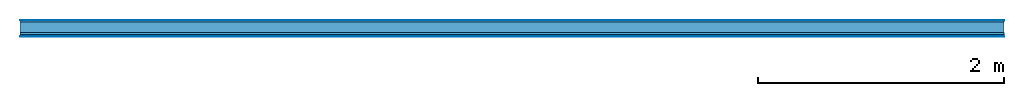
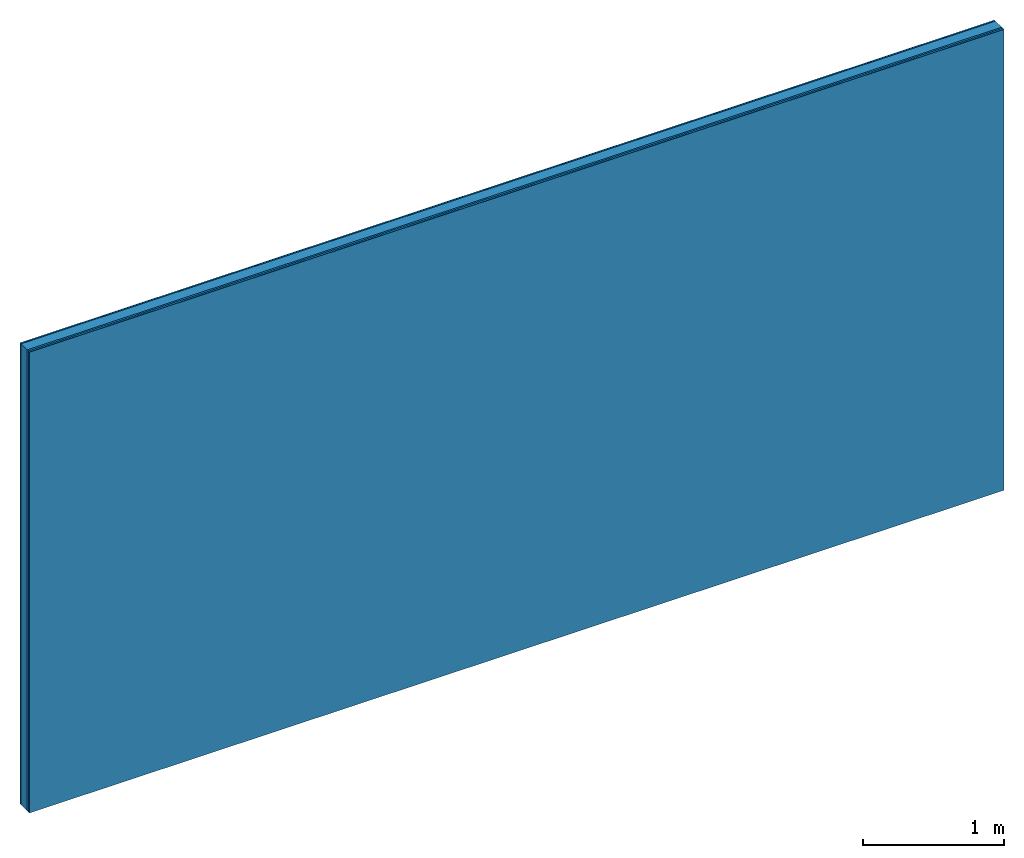
# One storey: 5 plates, 1 member, 1 element without a shape of its own.
"""IFC4 building model written with IfcOpenShell, lengths in metres."""

from ifc_helpers import new_model, si_unit, derived_unit, direction, frame, frame_2d, origin, origin_with_axes, place, context, project, spatial, rectangle, extrude, material, layer, layer_set, type_object, element, aggregate, save


model = new_model("IFC4")

# Units and contexts
plan_context = context("Plan", 3, precision=1e-05, world=origin(), true_north=direction((0.0, 1.0)))
model_context = context("Model", 3, precision=1e-05, world=origin(), true_north=direction((0.0, 1.0)))
ifc_project = project(units=[si_unit("LENGTHUNIT", "METRE"), derived_unit("SOUNDPRESSUREUNIT", [(si_unit("PRESSUREUNIT", "PASCAL", prefix="MICRO"), 0)]), si_unit("ENERGYUNIT", "JOULE", prefix="MEGA"), si_unit("MASSUNIT", "GRAM", prefix="KILO"), derived_unit("THERMALTRANSMITTANCEUNIT", [(si_unit("POWERUNIT", "WATT"), 1), (si_unit("AREAUNIT", "SQUARE_METRE"), -1), (si_unit("THERMODYNAMICTEMPERATUREUNIT", "KELVIN"), -1)]), derived_unit("AREADENSITYUNIT", [(si_unit("MASSUNIT", "GRAM", prefix="KILO"), 1), (si_unit("AREAUNIT", "SQUARE_METRE"), -1)]), derived_unit("USERDEFINED", [(si_unit("ENERGYUNIT", "JOULE", prefix="MEGA"), 1), (si_unit("AREAUNIT", "SQUARE_METRE"), -1)])], contexts=[plan_context, model_context])

# Site, building, storey
site = spatial("IfcSite", under=ifc_project)
building_placement = place(None, origin())
building = spatial("IfcBuilding", under=site, at=building_placement)
storey_placement = place(building_placement, origin())
storey = spatial("IfcBuildingStorey", under=building, at=storey_placement)

# Wall, member, plates
ifc_material_1 = material(Category="04.001")
ifc_layer_1 = layer(ifc_material_1, 0.003, Name="Surface")
ifc_material_2 = material(Name="Plasterboard type A", Category="03.008")
ifc_layer_2 = layer(ifc_material_2, 0.0125, Name="1st layer")
ifc_material_3 = material(Name="of the art")
ifc_layer_3 = layer(ifc_material_3, 0.0, Name="Bond")
ifc_layer_4 = layer(None, 0.087, Name="Support")
ifc_layer_5 = layer(ifc_material_3, 0.0, Name="Bond")
ifc_material_4 = material(Name="DFH2IR Knauf Diamant hard- plasterboard", Category="03.007")
ifc_layer_6 = layer(ifc_material_4, 0.015, Name="1st layer")
ifc_layer_7 = layer(ifc_material_4, 0.015, Name="2nd layer")
ifc_layer_8 = layer(ifc_material_1, 0.003, Name="Surface")
ifc_layer_set = layer_set([ifc_layer_1, ifc_layer_2, ifc_layer_3, ifc_layer_4, ifc_layer_5, ifc_layer_6, ifc_layer_7, ifc_layer_8])
wall_type = type_object("IfcWallType", Name="C0367", PredefinedType="NOTDEFINED", material=ifc_layer_set)
wall_placement = place(None, frame((0.0, 0.0, 0.0), z_axis=(0.0, -1.0, 0.0), x_axis=(1.0, 0.0, 0.0)))
wall = element("IfcWall", 1, at=wall_placement, inside=storey, type_object=wall_type, material=ifc_layer_set, Name="Wall #1")
ifc_material_5 = material(Name="Solid timber panel")
member_placement = place(wall_placement, origin())
member = element("IfcMember", 2, at=member_placement, material=ifc_material_5, Name="Support", context=plan_context, shape_type="SweptSolid", body=[
    extrude(rectangle(XDim=1.0, YDim=0.087, at=frame_2d((0.5, 0.0435), x_axis=(1.0, 0.0))), frame((0.0, 4.0, 0.0155), z_axis=(0.0, -1.0, 0.0), x_axis=(1.0, 0.0, 0.0)), (0.0, 0.0, 1.0), 4.0),
    extrude(rectangle(XDim=1.0, YDim=0.087, at=frame_2d((0.5, 0.0435), x_axis=(1.0, 0.0))), frame((1.0, 4.0, 0.0155), z_axis=(0.0, -1.0, 0.0), x_axis=(1.0, 0.0, 0.0)), (0.0, 0.0, 1.0), 4.0),
    extrude(rectangle(XDim=1.0, YDim=0.087, at=frame_2d((0.5, 0.0435), x_axis=(1.0, 0.0))), frame((2.0, 4.0, 0.0155), z_axis=(0.0, -1.0, 0.0), x_axis=(1.0, 0.0, 0.0)), (0.0, 0.0, 1.0), 4.0),
    extrude(rectangle(XDim=1.0, YDim=0.087, at=frame_2d((0.5, 0.0435), x_axis=(1.0, 0.0))), frame((3.0, 4.0, 0.0155), z_axis=(0.0, -1.0, 0.0), x_axis=(1.0, 0.0, 0.0)), (0.0, 0.0, 1.0), 4.0),
    extrude(rectangle(XDim=1.0, YDim=0.087, at=frame_2d((0.5, 0.0435), x_axis=(1.0, 0.0))), frame((4.0, 4.0, 0.0155), z_axis=(0.0, -1.0, 0.0), x_axis=(1.0, 0.0, 0.0)), (0.0, 0.0, 1.0), 4.0),
    extrude(rectangle(XDim=1.0, YDim=0.087, at=frame_2d((0.5, 0.0435), x_axis=(1.0, 0.0))), frame((5.0, 4.0, 0.0155), z_axis=(0.0, -1.0, 0.0), x_axis=(1.0, 0.0, 0.0)), (0.0, 0.0, 1.0), 4.0),
    extrude(rectangle(XDim=1.0, YDim=0.087, at=frame_2d((0.5, 0.0435), x_axis=(1.0, 0.0))), frame((6.0, 4.0, 0.0155), z_axis=(0.0, -1.0, 0.0), x_axis=(1.0, 0.0, 0.0)), (0.0, 0.0, 1.0), 4.0),
    extrude(rectangle(XDim=1.0, YDim=0.087, at=frame_2d((0.5, 0.0435), x_axis=(1.0, 0.0))), frame((7.0, 4.0, 0.0155), z_axis=(0.0, -1.0, 0.0), x_axis=(1.0, 0.0, 0.0)), (0.0, 0.0, 1.0), 4.0),
])
plate_1_placement = place(wall_placement, origin())
plate_1 = element("IfcPlate", 3, at=plate_1_placement, material=ifc_material_1, Name="Surface", context=plan_context, shape_type="SweptSolid", body=[
    extrude(rectangle(XDim=8.0, YDim=4.0, at=frame_2d((4.0, 2.0), x_axis=(1.0, 0.0))), origin_with_axes(), (0.0, 0.0, 1.0), 0.003),
])
plate_2_placement = place(wall_placement, origin())
plate_2 = element("IfcPlate", 4, at=plate_2_placement, material=ifc_material_2, Name="1st layer", context=plan_context, shape_type="SweptSolid", body=[
    extrude(rectangle(XDim=8.0, YDim=4.0, at=frame_2d((4.0, 2.0), x_axis=(1.0, 0.0))), frame((0.0, 0.0, 0.003), z_axis=(0.0, 0.0, 1.0), x_axis=(1.0, 0.0, 0.0)), (0.0, 0.0, 1.0), 0.0125),
])
plate_3_placement = place(wall_placement, origin())
plate_3 = element("IfcPlate", 5, at=plate_3_placement, material=ifc_material_4, Name="1st layer", context=plan_context, shape_type="SweptSolid", body=[
    extrude(rectangle(XDim=8.0, YDim=4.0, at=frame_2d((4.0, 2.0), x_axis=(1.0, 0.0))), frame((0.0, 0.0, 0.1025), z_axis=(0.0, 0.0, 1.0), x_axis=(1.0, 0.0, 0.0)), (0.0, 0.0, 1.0), 0.015),
])
plate_4_placement = place(wall_placement, origin())
plate_4 = element("IfcPlate", 6, at=plate_4_placement, material=ifc_material_4, Name="2nd layer", context=plan_context, shape_type="SweptSolid", body=[
    extrude(rectangle(XDim=8.0, YDim=4.0, at=frame_2d((4.0, 2.0), x_axis=(1.0, 0.0))), frame((0.0, 0.0, 0.1175), z_axis=(0.0, 0.0, 1.0), x_axis=(1.0, 0.0, 0.0)), (0.0, 0.0, 1.0), 0.015),
])
plate_5_placement = place(wall_placement, origin())
plate_5 = element("IfcPlate", 7, at=plate_5_placement, material=ifc_material_1, Name="Surface", context=plan_context, shape_type="SweptSolid", body=[
    extrude(rectangle(XDim=8.0, YDim=4.0, at=frame_2d((4.0, 2.0), x_axis=(1.0, 0.0))), frame((0.0, 0.0, 0.1325), z_axis=(0.0, 0.0, 1.0), x_axis=(1.0, 0.0, 0.0)), (0.0, 0.0, 1.0), 0.003),
])
aggregate(wall, [plate_1, plate_2, member, plate_3, plate_4, plate_5])

save(model, "model.ifc")
